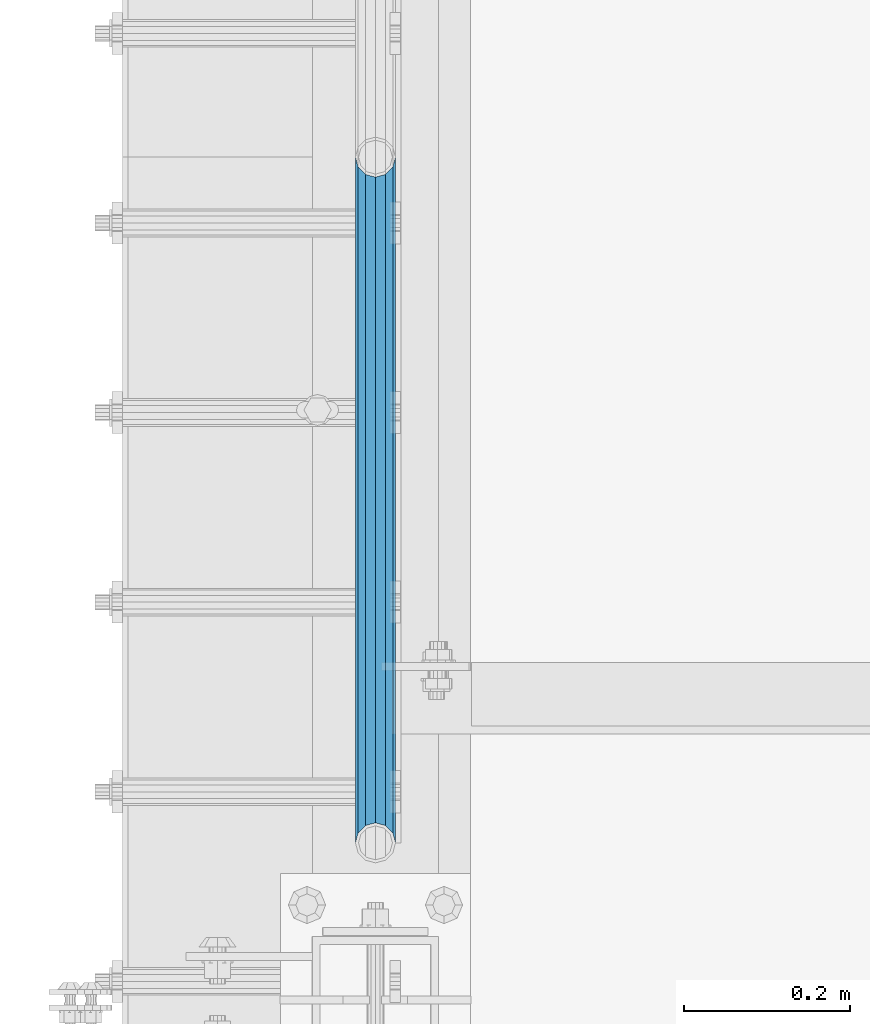
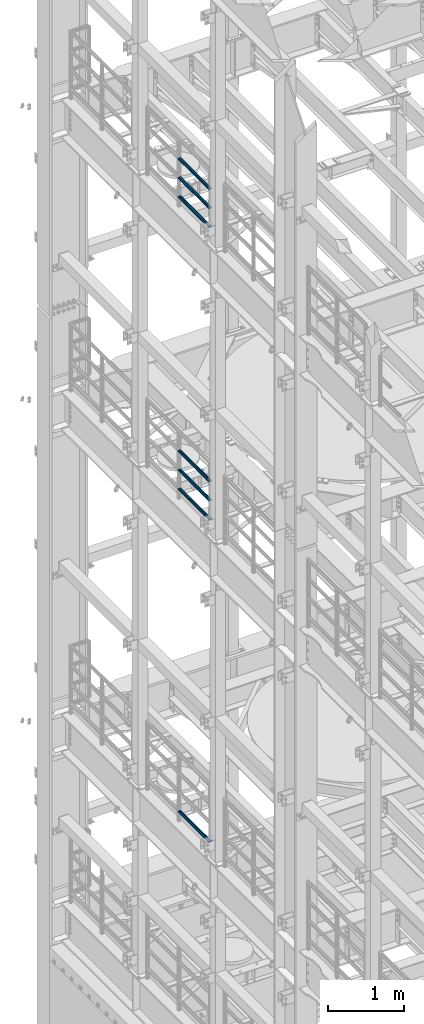
# One storey, part 1303 of 1876: 7 beams, 3 elements without a shape of their own.
"""IFC2X3 building model written with IfcOpenShell, lengths in millimetres."""

from ifc_helpers import new_model, si_unit, frame, origin_with_axes, place, context, subcontext, project, spatial, faceted_brep, material, type_object, element, aggregate, save


model = new_model("IFC2X3")

# Units and contexts
model_context = context("Model", 3, precision=1e-05, world=origin_with_axes())
body_context = subcontext(model_context, "Body", "Model", "MODEL_VIEW")
ifc_project = project(units=[si_unit("LENGTHUNIT", "METRE", prefix="MILLI"), si_unit("AREAUNIT", "SQUARE_METRE"), si_unit("VOLUMEUNIT", "CUBIC_METRE"), si_unit("MASSUNIT", "GRAM", prefix="KILO"), si_unit("TIMEUNIT", "SECOND"), si_unit("PLANEANGLEUNIT", "RADIAN"), si_unit("SOLIDANGLEUNIT", "STERADIAN"), si_unit("THERMODYNAMICTEMPERATUREUNIT", "DEGREE_CELSIUS"), si_unit("LUMINOUSINTENSITYUNIT", "LUMEN")], contexts=[model_context])

# Site, building, storey
site_placement = place(None, origin_with_axes())
site = spatial("IfcSite", under=ifc_project, at=site_placement, CompositionType="ELEMENT")
building_placement = place(site_placement, origin_with_axes())
building = spatial("IfcBuilding", under=site, at=building_placement, Name="Undefined", CompositionType="ELEMENT")
storey_placement = place(building_placement, origin_with_axes())
storey = spatial("IfcBuildingStorey", under=building, at=storey_placement, Name="Undefined", CompositionType="ELEMENT", Elevation=0.0)

# Assembly, beams
assembly_1_placement = place(storey_placement, origin_with_axes())
assembly_1 = element("IfcElementAssembly", 1, at=assembly_1_placement, inside=storey, Name="RAIL", AssemblyPlace="NOTDEFINED", PredefinedType="RIGID_FRAME")
ifc_material = material()
beam_type = type_object("IfcBeamType", Name="PIPE1-1/2SCH40", PredefinedType="NOTDEFINED")
beam_1_placement = place(assembly_1_placement, frame((-1.81898940354586e-12, 10668.0, 18145.125), z_axis=(0.0, 0.0, 1.0), x_axis=(0.0, -1.0, 0.0)))
beam_1 = element("IfcBeam", 2, at=beam_1_placement, type_object=beam_type, material=ifc_material, Name="RAIL", ObjectType="PIPE1-1/2SCH40", context=body_context, shape_type="Brep", body=[
    faceted_brep([(805.872807006681, -12.0649999999996, 20.8971929933177), (805.872807006683, -12.0649999999996, 15.8661214311796), (805.379378568819, -10.2235000000001, 17.7076214311819), (802.640000000001, 0.0, 20.4470000000001), (802.640000000001, 0.0, 24.130000000001), (805.379378568819, 10.2235000000001, 17.7076214311819), (805.872807006683, 12.0649999999996, 15.8661214311796), (805.872807006681, 12.0649999999996, 20.8971929933177), (826.77, 24.1300000000001, 0.0), (814.705, 20.8971929933186, 12.0649999999987), (814.705, 20.8971929933186, -12.0649999999987), (811.515428437862, 17.7076214311801, 10.2235000000001), (814.254807006682, 20.4470000000001, 0.0), (811.515428437862, 17.7076214311801, -10.2235000000001), (805.872807006683, 12.0649999999996, -15.8661214311796), (805.872807006681, 12.0649999999996, -20.8971929933177), (805.379378568819, 10.2235000000001, -17.7076214311819), (802.640000000001, 0.0, -20.4470000000001), (802.640000000001, 0.0, -24.130000000001), (805.872807006683, -12.0649999999996, -15.8661214311796), (805.872807006681, -12.0649999999996, -20.8971929933177), (805.379378568819, -10.2235000000001, -17.7076214311819), (826.77, -24.1300000000001, 0.0), (814.705, -20.8971929933186, -12.0649999999987), (814.705, -20.8971929933186, 12.0649999999987), (811.515428437862, -17.7076214311801, -10.2235000000001), (814.254807006682, -20.4470000000001, 0.0), (811.515428437862, -17.7076214311801, 10.2235000000001), (12.0650000000064, -20.8971929933177, -12.0649999999987), (20.8971929933249, -12.0650000000005, -20.8971929933177), (0.0, 24.1299999999992, 0.0), (12.0650000000064, 20.8971929933177, -12.0649999999987), (12.0650000000064, 20.8971929933177, 12.0649999999987), (20.8971929933249, 12.0650000000005, 20.8971929933177), (24.1300000000064, 0.0, 24.130000000001), (20.8971929933249, 12.0650000000005, -20.8971929933177), (24.1300000000063, 0.0, -24.130000000001), (24.1300000000063, 0.0, -20.4470000000001), (20.8971929933249, -12.0650000000005, -15.8661214311796), (21.3906214311868, -10.2235000000001, -17.7076214311819), (21.3906214311868, 10.2235000000001, -17.7076214311819), (20.8971929933249, 12.0650000000005, -15.8661214311796), (15.2545715621445, 17.7076214311801, -10.2235000000001), (12.5151929933249, 20.4470000000001, 0.0), (15.2545715621445, 17.7076214311801, 10.2235000000001), (20.8971929933249, 12.0650000000005, 15.8661214311796), (21.3906214311868, 10.2235000000001, 17.7076214311819), (24.1300000000064, 0.0, 20.4470000000001), (21.3906214311868, -10.2235000000001, 17.7076214311819), (20.8971929933249, -12.0650000000005, 15.8661214311796), (20.8971929933249, -12.0650000000005, 20.8971929933177), (12.0650000000064, -20.8971929933177, 12.0649999999987), (0.0, -24.1299999999992, 0.0), (15.2545715621445, -17.7076214311801, 10.2235000000001), (12.5151929933249, -20.4470000000001, 0.0), (15.2545715621445, -17.7076214311801, -10.2235000000001)], [[[0, 1, 2, 3, 4]], [[4, 3, 5, 6, 7]], [[8, 9, 10]], [[7, 6, 11, 12, 13, 14, 15, 10, 9]], [[16, 17, 18, 15, 14]], [[19, 20, 18, 17, 21]], [[22, 23, 24]], [[24, 23, 20, 19, 25, 26, 27, 1, 0]], [[28, 29, 20, 23]], [[30, 31, 32]], [[33, 34, 4, 7]], [[32, 33, 7, 9]], [[30, 32, 9, 8]], [[31, 30, 8, 10]], [[35, 31, 10, 15]], [[36, 35, 15, 18]], [[29, 36, 18, 20]], [[37, 36, 29, 38, 39]], [[40, 41, 35, 36, 37]], [[32, 31, 35, 41, 42, 43, 44, 45, 33]], [[33, 45, 46, 47, 34]], [[34, 47, 48, 49, 50]], [[34, 50, 0, 4]], [[50, 51, 24, 0]], [[51, 52, 22, 24]], [[52, 28, 23, 22]], [[51, 28, 52]], [[50, 49, 53, 54, 55, 38, 29, 28, 51]], [[55, 54, 26, 25]], [[21, 39, 38, 55, 25, 19]], [[37, 39, 21, 17]], [[40, 37, 17, 16]], [[42, 41, 40, 16, 14, 13]], [[43, 42, 13, 12]], [[44, 43, 12, 11]], [[5, 46, 45, 44, 11, 6]], [[47, 46, 5, 3]], [[48, 47, 3, 2]], [[53, 49, 48, 2, 1, 27]], [[54, 53, 27, 26]]]),
])
beam_2_placement = place(assembly_1_placement, frame((-1.81898940354586e-12, 9841.23, 18449.925), z_axis=(0.0, 0.0, -1.0), x_axis=(0.0, 1.0, 0.0)))
beam_2 = element("IfcBeam", 3, at=beam_2_placement, type_object=beam_type, material=ifc_material, Name="RAIL", ObjectType="PIPE1-1/2SCH40", context=body_context, shape_type="Brep", body=[
    faceted_brep([(0.0, 24.1299999999992, 0.0), (12.0650000000064, 20.8971929933177, -12.0649999999987), (12.0650000000064, 20.8971929933177, 12.0649999999987), (12.0650000000064, -20.8971929933177, 12.0649999999987), (12.0650000000064, -20.8971929933177, -12.0649999999987), (0.0, -24.1299999999992, 0.0), (20.8971929933249, -12.0650000000005, 20.8971929933177), (20.8971929933249, -12.0650000000005, 15.8661214311796), (15.2545715621445, -17.7076214311801, 10.2235000000001), (12.5151929933249, -20.4470000000001, 0.0), (15.2545715621445, -17.7076214311801, -10.2235000000001), (20.8971929933249, -12.0650000000005, -15.8661214311796), (20.8971929933249, -12.0650000000005, -20.8971929933177), (24.1300000000063, 0.0, -20.4470000000001), (24.1300000000063, 0.0, -24.130000000001), (21.3906214311868, -10.2235000000001, -17.7076214311819), (21.3906214311868, 10.2235000000001, -17.7076214311819), (20.8971929933249, 12.0650000000005, -15.8661214311796), (20.8971929933249, 12.0650000000005, -20.8971929933177), (15.2545715621445, 17.7076214311801, -10.2235000000001), (12.5151929933249, 20.4470000000001, 0.0), (15.2545715621445, 17.7076214311801, 10.2235000000001), (20.8971929933249, 12.0650000000005, 15.8661214311796), (20.8971929933249, 12.0650000000005, 20.8971929933177), (21.3906214311868, 10.2235000000001, 17.7076214311819), (24.1300000000064, 0.0, 20.4470000000001), (24.1300000000064, 0.0, 24.130000000001), (21.3906214311868, -10.2235000000001, 17.7076214311819), (826.77, 24.1300000000001, 0.0), (814.705, 20.8971929933186, -12.0649999999987), (805.872807006681, 12.0649999999996, -20.8971929933177), (826.77, -24.1300000000001, 0.0), (814.705, -20.8971929933186, -12.0649999999987), (814.705, -20.8971929933186, 12.0649999999987), (805.872807006681, -12.0649999999996, 20.8971929933177), (805.872807006681, -12.0649999999996, -20.8971929933177), (802.640000000001, 0.0, -24.130000000001), (805.379378568819, 10.2235000000001, -17.7076214311819), (802.640000000001, 0.0, -20.4470000000001), (805.872807006683, 12.0649999999996, -15.8661214311796), (805.872807006683, -12.0649999999996, -15.8661214311796), (805.379378568819, -10.2235000000001, -17.7076214311819), (811.515428437862, -17.7076214311801, -10.2235000000001), (814.254807006682, -20.4470000000001, 0.0), (811.515428437862, -17.7076214311801, 10.2235000000001), (805.872807006683, -12.0649999999996, 15.8661214311796), (805.379378568819, -10.2235000000001, 17.7076214311819), (802.640000000001, 0.0, 20.4470000000001), (802.640000000001, 0.0, 24.130000000001), (805.872807006681, 12.0649999999996, 20.8971929933177), (814.705, 20.8971929933186, 12.0649999999987), (805.872807006683, 12.0649999999996, 15.8661214311796), (811.515428437862, 17.7076214311801, 10.2235000000001), (814.254807006682, 20.4470000000001, 0.0), (811.515428437862, 17.7076214311801, -10.2235000000001), (805.379378568819, 10.2235000000001, 17.7076214311819)], [[[0, 1, 2]], [[3, 4, 5]], [[6, 7, 8, 9, 10, 11, 12, 4, 3]], [[13, 14, 12, 11, 15]], [[16, 17, 18, 14, 13]], [[2, 1, 18, 17, 19, 20, 21, 22, 23]], [[23, 22, 24, 25, 26]], [[26, 25, 27, 7, 6]], [[1, 0, 28, 29]], [[18, 1, 29, 30]], [[31, 32, 33]], [[6, 3, 33, 34]], [[3, 5, 31, 33]], [[5, 4, 32, 31]], [[4, 12, 35, 32]], [[12, 14, 36, 35]], [[14, 18, 30, 36]], [[37, 38, 36, 30, 39]], [[40, 35, 36, 38, 41]], [[33, 32, 35, 40, 42, 43, 44, 45, 34]], [[34, 45, 46, 47, 48]], [[26, 6, 34, 48]], [[2, 23, 49, 50]], [[23, 26, 48, 49]], [[0, 2, 50, 28]], [[28, 50, 29]], [[49, 51, 52, 53, 54, 39, 30, 29, 50]], [[48, 47, 55, 51, 49]], [[25, 24, 55, 47]], [[55, 24, 22, 21, 52, 51]], [[21, 20, 53, 52]], [[20, 19, 54, 53]], [[19, 17, 16, 37, 39, 54]], [[16, 13, 38, 37]], [[13, 15, 41, 38]], [[41, 15, 11, 10, 42, 40]], [[10, 9, 43, 42]], [[9, 8, 44, 43]], [[8, 7, 27, 46, 45, 44]], [[27, 25, 47, 46]]]),
])
beam_3_placement = place(assembly_1_placement, frame((-1.81898940354586e-12, 9841.23, 18754.725), z_axis=(0.0, 0.0, -1.0), x_axis=(0.0, 1.0, 0.0)))
beam_3 = element("IfcBeam", 4, at=beam_3_placement, type_object=beam_type, material=ifc_material, Name="RAIL", ObjectType="PIPE1-1/2SCH40", context=body_context, shape_type="Brep", body=[
    faceted_brep([(0.0, 24.1299999999992, 0.0), (12.0650000000064, 20.8971929933177, -12.0649999999987), (12.0650000000064, 20.8971929933177, 12.0649999999987), (12.0650000000064, -20.8971929933177, 12.0649999999987), (12.0650000000064, -20.8971929933177, -12.0649999999987), (0.0, -24.1299999999992, 0.0), (20.8971929933249, -12.0650000000005, 20.8971929933177), (20.8971929933249, -12.0650000000005, 15.8661214311796), (15.2545715621445, -17.7076214311801, 10.2235000000001), (12.5151929933249, -20.4470000000001, 0.0), (15.2545715621445, -17.7076214311801, -10.2235000000001), (20.8971929933249, -12.0650000000005, -15.8661214311796), (20.8971929933249, -12.0650000000005, -20.8971929933177), (24.1300000000063, 0.0, -20.4470000000001), (24.1300000000063, 0.0, -24.130000000001), (21.3906214311868, -10.2235000000001, -17.7076214311819), (21.3906214311868, 10.2235000000001, -17.7076214311819), (20.8971929933249, 12.0650000000005, -15.8661214311796), (20.8971929933249, 12.0650000000005, -20.8971929933177), (15.2545715621445, 17.7076214311801, -10.2235000000001), (12.5151929933249, 20.4470000000001, 0.0), (15.2545715621445, 17.7076214311801, 10.2235000000001), (20.8971929933249, 12.0650000000005, 15.8661214311796), (20.8971929933249, 12.0650000000005, 20.8971929933177), (21.3906214311868, 10.2235000000001, 17.7076214311819), (24.1300000000064, 0.0, 20.4470000000001), (24.1300000000064, 0.0, 24.130000000001), (21.3906214311868, -10.2235000000001, 17.7076214311819), (826.77, 24.1300000000001, 0.0), (814.705, 20.8971929933186, -12.0649999999987), (805.872807006681, 12.0649999999996, -20.8971929933177), (826.77, -24.1300000000001, 0.0), (814.705, -20.8971929933186, -12.0649999999987), (814.705, -20.8971929933186, 12.0649999999987), (805.872807006681, -12.0649999999996, 20.8971929933177), (805.872807006681, -12.0649999999996, -20.8971929933177), (802.640000000001, 0.0, -24.130000000001), (805.379378568819, 10.2235000000001, -17.7076214311819), (802.640000000001, 0.0, -20.4470000000001), (805.872807006683, 12.0649999999996, -15.8661214311796), (805.872807006683, -12.0649999999996, -15.8661214311796), (805.379378568819, -10.2235000000001, -17.7076214311819), (811.515428437862, -17.7076214311801, -10.2235000000001), (814.254807006682, -20.4470000000001, 0.0), (811.515428437862, -17.7076214311801, 10.2235000000001), (805.872807006683, -12.0649999999996, 15.8661214311796), (805.379378568819, -10.2235000000001, 17.7076214311819), (802.640000000001, 0.0, 20.4470000000001), (802.640000000001, 0.0, 24.130000000001), (805.872807006681, 12.0649999999996, 20.8971929933177), (814.705, 20.8971929933186, 12.0649999999987), (805.872807006683, 12.0649999999996, 15.8661214311796), (811.515428437862, 17.7076214311801, 10.2235000000001), (814.254807006682, 20.4470000000001, 0.0), (811.515428437862, 17.7076214311801, -10.2235000000001), (805.379378568819, 10.2235000000001, 17.7076214311819)], [[[0, 1, 2]], [[3, 4, 5]], [[6, 7, 8, 9, 10, 11, 12, 4, 3]], [[13, 14, 12, 11, 15]], [[16, 17, 18, 14, 13]], [[2, 1, 18, 17, 19, 20, 21, 22, 23]], [[23, 22, 24, 25, 26]], [[26, 25, 27, 7, 6]], [[1, 0, 28, 29]], [[18, 1, 29, 30]], [[31, 32, 33]], [[6, 3, 33, 34]], [[3, 5, 31, 33]], [[5, 4, 32, 31]], [[4, 12, 35, 32]], [[12, 14, 36, 35]], [[14, 18, 30, 36]], [[37, 38, 36, 30, 39]], [[40, 35, 36, 38, 41]], [[33, 32, 35, 40, 42, 43, 44, 45, 34]], [[34, 45, 46, 47, 48]], [[26, 6, 34, 48]], [[2, 23, 49, 50]], [[23, 26, 48, 49]], [[0, 2, 50, 28]], [[28, 50, 29]], [[49, 51, 52, 53, 54, 39, 30, 29, 50]], [[48, 47, 55, 51, 49]], [[25, 24, 55, 47]], [[55, 24, 22, 21, 52, 51]], [[21, 20, 53, 52]], [[20, 19, 54, 53]], [[19, 17, 16, 37, 39, 54]], [[16, 13, 38, 37]], [[13, 15, 41, 38]], [[41, 15, 11, 10, 42, 40]], [[10, 9, 43, 42]], [[9, 8, 44, 43]], [[8, 7, 27, 46, 45, 44]], [[27, 25, 47, 46]]]),
])
aggregate(assembly_1, [beam_1, beam_2, beam_3])

assembly_2_placement = place(storey_placement, origin_with_axes())
assembly_2 = element("IfcElementAssembly", 5, at=assembly_2_placement, inside=storey, Name="RAIL", AssemblyPlace="NOTDEFINED", PredefinedType="RIGID_FRAME")
beam_4_placement = place(assembly_2_placement, frame((-1.81898940354586e-12, 10668.0, 13471.525), z_axis=(0.0, 0.0, 1.0), x_axis=(0.0, -1.0, 0.0)))
beam_4 = element("IfcBeam", 6, at=beam_4_placement, type_object=beam_type, material=ifc_material, Name="RAIL", ObjectType="PIPE1-1/2SCH40", context=body_context, shape_type="Brep", body=[
    faceted_brep([(805.872807006681, -12.0649999999996, 20.8971929933177), (805.872807006683, -12.0649999999996, 15.8661214311796), (805.379378568819, -10.2235000000001, 17.7076214311819), (802.640000000001, 0.0, 20.4470000000001), (802.640000000001, 0.0, 24.130000000001), (805.379378568819, 10.2235000000001, 17.7076214311819), (805.872807006683, 12.0649999999996, 15.8661214311796), (805.872807006681, 12.0649999999996, 20.8971929933177), (826.77, 24.1300000000001, 0.0), (814.705, 20.8971929933186, 12.0649999999987), (814.705, 20.8971929933186, -12.0649999999987), (811.515428437862, 17.7076214311801, 10.2235000000001), (814.254807006682, 20.4470000000001, 0.0), (811.515428437862, 17.7076214311801, -10.2235000000001), (805.872807006683, 12.0649999999996, -15.8661214311796), (805.872807006681, 12.0649999999996, -20.8971929933177), (805.379378568819, 10.2235000000001, -17.7076214311819), (802.640000000001, 0.0, -20.4470000000001), (802.640000000001, 0.0, -24.130000000001), (805.872807006683, -12.0649999999996, -15.8661214311796), (805.872807006681, -12.0649999999996, -20.8971929933177), (805.379378568819, -10.2235000000001, -17.7076214311819), (826.77, -24.1300000000001, 0.0), (814.705, -20.8971929933186, -12.0649999999987), (814.705, -20.8971929933186, 12.0649999999987), (811.515428437862, -17.7076214311801, -10.2235000000001), (814.254807006682, -20.4470000000001, 0.0), (811.515428437862, -17.7076214311801, 10.2235000000001), (12.0650000000064, -20.8971929933177, -12.0649999999987), (20.8971929933249, -12.0650000000005, -20.8971929933177), (0.0, 24.1299999999992, 0.0), (12.0650000000064, 20.8971929933177, -12.0649999999987), (12.0650000000064, 20.8971929933177, 12.0649999999987), (20.8971929933249, 12.0650000000005, 20.8971929933177), (24.1300000000064, 0.0, 24.130000000001), (20.8971929933249, 12.0650000000005, -20.8971929933177), (24.1300000000063, 0.0, -24.130000000001), (24.1300000000063, 0.0, -20.4470000000001), (20.8971929933249, -12.0650000000005, -15.8661214311796), (21.3906214311868, -10.2235000000001, -17.7076214311819), (21.3906214311868, 10.2235000000001, -17.7076214311819), (20.8971929933249, 12.0650000000005, -15.8661214311796), (15.2545715621445, 17.7076214311801, -10.2235000000001), (12.5151929933249, 20.4470000000001, 0.0), (15.2545715621445, 17.7076214311801, 10.2235000000001), (20.8971929933249, 12.0650000000005, 15.8661214311796), (21.3906214311868, 10.2235000000001, 17.7076214311819), (24.1300000000064, 0.0, 20.4470000000001), (21.3906214311868, -10.2235000000001, 17.7076214311819), (20.8971929933249, -12.0650000000005, 15.8661214311796), (20.8971929933249, -12.0650000000005, 20.8971929933177), (12.0650000000064, -20.8971929933177, 12.0649999999987), (0.0, -24.1299999999992, 0.0), (15.2545715621445, -17.7076214311801, 10.2235000000001), (12.5151929933249, -20.4470000000001, 0.0), (15.2545715621445, -17.7076214311801, -10.2235000000001)], [[[0, 1, 2, 3, 4]], [[4, 3, 5, 6, 7]], [[8, 9, 10]], [[7, 6, 11, 12, 13, 14, 15, 10, 9]], [[16, 17, 18, 15, 14]], [[19, 20, 18, 17, 21]], [[22, 23, 24]], [[24, 23, 20, 19, 25, 26, 27, 1, 0]], [[28, 29, 20, 23]], [[30, 31, 32]], [[33, 34, 4, 7]], [[32, 33, 7, 9]], [[30, 32, 9, 8]], [[31, 30, 8, 10]], [[35, 31, 10, 15]], [[36, 35, 15, 18]], [[29, 36, 18, 20]], [[37, 36, 29, 38, 39]], [[40, 41, 35, 36, 37]], [[32, 31, 35, 41, 42, 43, 44, 45, 33]], [[33, 45, 46, 47, 34]], [[34, 47, 48, 49, 50]], [[34, 50, 0, 4]], [[50, 51, 24, 0]], [[51, 52, 22, 24]], [[52, 28, 23, 22]], [[51, 28, 52]], [[50, 49, 53, 54, 55, 38, 29, 28, 51]], [[55, 54, 26, 25]], [[21, 39, 38, 55, 25, 19]], [[37, 39, 21, 17]], [[40, 37, 17, 16]], [[42, 41, 40, 16, 14, 13]], [[43, 42, 13, 12]], [[44, 43, 12, 11]], [[5, 46, 45, 44, 11, 6]], [[47, 46, 5, 3]], [[48, 47, 3, 2]], [[53, 49, 48, 2, 1, 27]], [[54, 53, 27, 26]]]),
])
beam_5_placement = place(assembly_2_placement, frame((-1.81898940354586e-12, 9841.23, 13776.325), z_axis=(0.0, 0.0, -1.0), x_axis=(0.0, 1.0, 0.0)))
beam_5 = element("IfcBeam", 7, at=beam_5_placement, type_object=beam_type, material=ifc_material, Name="RAIL", ObjectType="PIPE1-1/2SCH40", context=body_context, shape_type="Brep", body=[
    faceted_brep([(0.0, 24.1299999999992, 0.0), (12.0650000000064, 20.8971929933177, -12.0649999999987), (12.0650000000064, 20.8971929933177, 12.0649999999987), (12.0650000000064, -20.8971929933177, 12.0649999999987), (12.0650000000064, -20.8971929933177, -12.0649999999987), (0.0, -24.1299999999992, 0.0), (20.8971929933249, -12.0650000000005, 20.8971929933177), (20.8971929933249, -12.0650000000005, 15.8661214311796), (15.2545715621445, -17.7076214311801, 10.2235000000001), (12.5151929933249, -20.4470000000001, 0.0), (15.2545715621445, -17.7076214311801, -10.2235000000001), (20.8971929933249, -12.0650000000005, -15.8661214311796), (20.8971929933249, -12.0650000000005, -20.8971929933177), (24.1300000000063, 0.0, -20.4470000000001), (24.1300000000063, 0.0, -24.130000000001), (21.3906214311868, -10.2235000000001, -17.7076214311819), (21.3906214311868, 10.2235000000001, -17.7076214311819), (20.8971929933249, 12.0650000000005, -15.8661214311796), (20.8971929933249, 12.0650000000005, -20.8971929933177), (15.2545715621445, 17.7076214311801, -10.2235000000001), (12.5151929933249, 20.4470000000001, 0.0), (15.2545715621445, 17.7076214311801, 10.2235000000001), (20.8971929933249, 12.0650000000005, 15.8661214311796), (20.8971929933249, 12.0650000000005, 20.8971929933177), (21.3906214311868, 10.2235000000001, 17.7076214311819), (24.1300000000064, 0.0, 20.4470000000001), (24.1300000000064, 0.0, 24.130000000001), (21.3906214311868, -10.2235000000001, 17.7076214311819), (826.77, 24.1300000000001, 0.0), (814.705, 20.8971929933186, -12.0649999999987), (805.872807006681, 12.0649999999996, -20.8971929933177), (826.77, -24.1300000000001, 0.0), (814.705, -20.8971929933186, -12.0649999999987), (814.705, -20.8971929933186, 12.0649999999987), (805.872807006681, -12.0649999999996, 20.8971929933177), (805.872807006681, -12.0649999999996, -20.8971929933177), (802.640000000001, 0.0, -24.130000000001), (805.379378568819, 10.2235000000001, -17.7076214311819), (802.640000000001, 0.0, -20.4470000000001), (805.872807006683, 12.0649999999996, -15.8661214311796), (805.872807006683, -12.0649999999996, -15.8661214311796), (805.379378568819, -10.2235000000001, -17.7076214311819), (811.515428437862, -17.7076214311801, -10.2235000000001), (814.254807006682, -20.4470000000001, 0.0), (811.515428437862, -17.7076214311801, 10.2235000000001), (805.872807006683, -12.0649999999996, 15.8661214311796), (805.379378568819, -10.2235000000001, 17.7076214311819), (802.640000000001, 0.0, 20.4470000000001), (802.640000000001, 0.0, 24.130000000001), (805.872807006681, 12.0649999999996, 20.8971929933177), (814.705, 20.8971929933186, 12.0649999999987), (805.872807006683, 12.0649999999996, 15.8661214311796), (811.515428437862, 17.7076214311801, 10.2235000000001), (814.254807006682, 20.4470000000001, 0.0), (811.515428437862, 17.7076214311801, -10.2235000000001), (805.379378568819, 10.2235000000001, 17.7076214311819)], [[[0, 1, 2]], [[3, 4, 5]], [[6, 7, 8, 9, 10, 11, 12, 4, 3]], [[13, 14, 12, 11, 15]], [[16, 17, 18, 14, 13]], [[2, 1, 18, 17, 19, 20, 21, 22, 23]], [[23, 22, 24, 25, 26]], [[26, 25, 27, 7, 6]], [[1, 0, 28, 29]], [[18, 1, 29, 30]], [[31, 32, 33]], [[6, 3, 33, 34]], [[3, 5, 31, 33]], [[5, 4, 32, 31]], [[4, 12, 35, 32]], [[12, 14, 36, 35]], [[14, 18, 30, 36]], [[37, 38, 36, 30, 39]], [[40, 35, 36, 38, 41]], [[33, 32, 35, 40, 42, 43, 44, 45, 34]], [[34, 45, 46, 47, 48]], [[26, 6, 34, 48]], [[2, 23, 49, 50]], [[23, 26, 48, 49]], [[0, 2, 50, 28]], [[28, 50, 29]], [[49, 51, 52, 53, 54, 39, 30, 29, 50]], [[48, 47, 55, 51, 49]], [[25, 24, 55, 47]], [[55, 24, 22, 21, 52, 51]], [[21, 20, 53, 52]], [[20, 19, 54, 53]], [[19, 17, 16, 37, 39, 54]], [[16, 13, 38, 37]], [[13, 15, 41, 38]], [[41, 15, 11, 10, 42, 40]], [[10, 9, 43, 42]], [[9, 8, 44, 43]], [[8, 7, 27, 46, 45, 44]], [[27, 25, 47, 46]]]),
])
beam_6_placement = place(assembly_2_placement, frame((-1.81898940354586e-12, 9841.23, 14081.125), z_axis=(0.0, 0.0, -1.0), x_axis=(0.0, 1.0, 0.0)))
beam_6 = element("IfcBeam", 8, at=beam_6_placement, type_object=beam_type, material=ifc_material, Name="RAIL", ObjectType="PIPE1-1/2SCH40", context=body_context, shape_type="Brep", body=[
    faceted_brep([(0.0, 24.1299999999992, 0.0), (12.0650000000064, 20.8971929933177, -12.0649999999987), (12.0650000000064, 20.8971929933177, 12.0649999999987), (12.0650000000064, -20.8971929933177, 12.0649999999987), (12.0650000000064, -20.8971929933177, -12.0649999999987), (0.0, -24.1299999999992, 0.0), (20.8971929933249, -12.0650000000005, 20.8971929933177), (20.8971929933249, -12.0650000000005, 15.8661214311796), (15.2545715621445, -17.7076214311801, 10.2235000000001), (12.5151929933249, -20.4470000000001, 0.0), (15.2545715621445, -17.7076214311801, -10.2235000000001), (20.8971929933249, -12.0650000000005, -15.8661214311796), (20.8971929933249, -12.0650000000005, -20.8971929933177), (24.1300000000063, 0.0, -20.4470000000001), (24.1300000000063, 0.0, -24.130000000001), (21.3906214311868, -10.2235000000001, -17.7076214311819), (21.3906214311868, 10.2235000000001, -17.7076214311819), (20.8971929933249, 12.0650000000005, -15.8661214311796), (20.8971929933249, 12.0650000000005, -20.8971929933177), (15.2545715621445, 17.7076214311801, -10.2235000000001), (12.5151929933249, 20.4470000000001, 0.0), (15.2545715621445, 17.7076214311801, 10.2235000000001), (20.8971929933249, 12.0650000000005, 15.8661214311796), (20.8971929933249, 12.0650000000005, 20.8971929933177), (21.3906214311868, 10.2235000000001, 17.7076214311819), (24.1300000000064, 0.0, 20.4470000000001), (24.1300000000064, 0.0, 24.130000000001), (21.3906214311868, -10.2235000000001, 17.7076214311819), (826.77, 24.1300000000001, 0.0), (814.705, 20.8971929933186, -12.0649999999987), (805.872807006681, 12.0649999999996, -20.8971929933177), (826.77, -24.1300000000001, 0.0), (814.705, -20.8971929933186, -12.0649999999987), (814.705, -20.8971929933186, 12.0649999999987), (805.872807006681, -12.0649999999996, 20.8971929933177), (805.872807006681, -12.0649999999996, -20.8971929933177), (802.640000000001, 0.0, -24.130000000001), (805.379378568819, 10.2235000000001, -17.7076214311819), (802.640000000001, 0.0, -20.4470000000001), (805.872807006683, 12.0649999999996, -15.8661214311796), (805.872807006683, -12.0649999999996, -15.8661214311796), (805.379378568819, -10.2235000000001, -17.7076214311819), (811.515428437862, -17.7076214311801, -10.2235000000001), (814.254807006682, -20.4470000000001, 0.0), (811.515428437862, -17.7076214311801, 10.2235000000001), (805.872807006683, -12.0649999999996, 15.8661214311796), (805.379378568819, -10.2235000000001, 17.7076214311819), (802.640000000001, 0.0, 20.4470000000001), (802.640000000001, 0.0, 24.130000000001), (805.872807006681, 12.0649999999996, 20.8971929933177), (814.705, 20.8971929933186, 12.0649999999987), (805.872807006683, 12.0649999999996, 15.8661214311796), (811.515428437862, 17.7076214311801, 10.2235000000001), (814.254807006682, 20.4470000000001, 0.0), (811.515428437862, 17.7076214311801, -10.2235000000001), (805.379378568819, 10.2235000000001, 17.7076214311819)], [[[0, 1, 2]], [[3, 4, 5]], [[6, 7, 8, 9, 10, 11, 12, 4, 3]], [[13, 14, 12, 11, 15]], [[16, 17, 18, 14, 13]], [[2, 1, 18, 17, 19, 20, 21, 22, 23]], [[23, 22, 24, 25, 26]], [[26, 25, 27, 7, 6]], [[1, 0, 28, 29]], [[18, 1, 29, 30]], [[31, 32, 33]], [[6, 3, 33, 34]], [[3, 5, 31, 33]], [[5, 4, 32, 31]], [[4, 12, 35, 32]], [[12, 14, 36, 35]], [[14, 18, 30, 36]], [[37, 38, 36, 30, 39]], [[40, 35, 36, 38, 41]], [[33, 32, 35, 40, 42, 43, 44, 45, 34]], [[34, 45, 46, 47, 48]], [[26, 6, 34, 48]], [[2, 23, 49, 50]], [[23, 26, 48, 49]], [[0, 2, 50, 28]], [[28, 50, 29]], [[49, 51, 52, 53, 54, 39, 30, 29, 50]], [[48, 47, 55, 51, 49]], [[25, 24, 55, 47]], [[55, 24, 22, 21, 52, 51]], [[21, 20, 53, 52]], [[20, 19, 54, 53]], [[19, 17, 16, 37, 39, 54]], [[16, 13, 38, 37]], [[13, 15, 41, 38]], [[41, 15, 11, 10, 42, 40]], [[10, 9, 43, 42]], [[9, 8, 44, 43]], [[8, 7, 27, 46, 45, 44]], [[27, 25, 47, 46]]]),
])
aggregate(assembly_2, [beam_4, beam_5, beam_6])

# Assembly, beam
assembly_3_placement = place(storey_placement, origin_with_axes())
assembly_3 = element("IfcElementAssembly", 9, at=assembly_3_placement, inside=storey, Name="RAIL", AssemblyPlace="NOTDEFINED", PredefinedType="RIGID_FRAME")
beam_7_placement = place(assembly_3_placement, frame((-1.81898940354586e-12, 10668.0, 8315.325), z_axis=(0.0, 0.0, 1.0), x_axis=(0.0, -1.0, 0.0)))
beam_7 = element("IfcBeam", 10, at=beam_7_placement, type_object=beam_type, material=ifc_material, Name="RAIL", ObjectType="PIPE1-1/2SCH40", context=body_context, shape_type="Brep", body=[
    faceted_brep([(805.872807006681, -12.0649999999996, 20.8971929933177), (805.872807006683, -12.0649999999996, 15.8661214311796), (805.379378568819, -10.2235000000001, 17.7076214311819), (802.640000000001, 0.0, 20.4470000000001), (802.640000000001, 0.0, 24.130000000001), (805.379378568819, 10.2235000000001, 17.7076214311819), (805.872807006683, 12.0649999999996, 15.8661214311796), (805.872807006681, 12.0649999999996, 20.8971929933177), (826.77, 24.1300000000001, 0.0), (814.705, 20.8971929933186, 12.0649999999987), (814.705, 20.8971929933186, -12.0649999999987), (811.515428437862, 17.7076214311801, 10.2235000000001), (814.254807006682, 20.4470000000001, 0.0), (811.515428437862, 17.7076214311801, -10.2235000000001), (805.872807006683, 12.0649999999996, -15.8661214311796), (805.872807006681, 12.0649999999996, -20.8971929933177), (805.379378568819, 10.2235000000001, -17.7076214311819), (802.640000000001, 0.0, -20.4470000000001), (802.640000000001, 0.0, -24.130000000001), (805.872807006683, -12.0649999999996, -15.8661214311796), (805.872807006681, -12.0649999999996, -20.8971929933177), (805.379378568819, -10.2235000000001, -17.7076214311819), (826.77, -24.1300000000001, 0.0), (814.705, -20.8971929933186, -12.0649999999987), (814.705, -20.8971929933186, 12.0649999999987), (811.515428437862, -17.7076214311801, -10.2235000000001), (814.254807006682, -20.4470000000001, 0.0), (811.515428437862, -17.7076214311801, 10.2235000000001), (12.0650000000064, -20.8971929933177, -12.0649999999987), (20.8971929933249, -12.0650000000005, -20.8971929933177), (0.0, 24.1299999999992, 0.0), (12.0650000000064, 20.8971929933177, -12.0649999999987), (12.0650000000064, 20.8971929933177, 12.0649999999987), (20.8971929933249, 12.0650000000005, 20.8971929933177), (24.1300000000064, 0.0, 24.130000000001), (20.8971929933249, 12.0650000000005, -20.8971929933177), (24.1300000000063, 0.0, -24.130000000001), (24.1300000000063, 0.0, -20.4470000000001), (20.8971929933249, -12.0650000000005, -15.8661214311796), (21.3906214311868, -10.2235000000001, -17.7076214311819), (21.3906214311868, 10.2235000000001, -17.7076214311819), (20.8971929933249, 12.0650000000005, -15.8661214311796), (15.2545715621445, 17.7076214311801, -10.2235000000001), (12.5151929933249, 20.4470000000001, 0.0), (15.2545715621445, 17.7076214311801, 10.2235000000001), (20.8971929933249, 12.0650000000005, 15.8661214311796), (21.3906214311868, 10.2235000000001, 17.7076214311819), (24.1300000000064, 0.0, 20.4470000000001), (21.3906214311868, -10.2235000000001, 17.7076214311819), (20.8971929933249, -12.0650000000005, 15.8661214311796), (20.8971929933249, -12.0650000000005, 20.8971929933177), (12.0650000000064, -20.8971929933177, 12.0649999999987), (0.0, -24.1299999999992, 0.0), (15.2545715621445, -17.7076214311801, 10.2235000000001), (12.5151929933249, -20.4470000000001, 0.0), (15.2545715621445, -17.7076214311801, -10.2235000000001)], [[[0, 1, 2, 3, 4]], [[4, 3, 5, 6, 7]], [[8, 9, 10]], [[7, 6, 11, 12, 13, 14, 15, 10, 9]], [[16, 17, 18, 15, 14]], [[19, 20, 18, 17, 21]], [[22, 23, 24]], [[24, 23, 20, 19, 25, 26, 27, 1, 0]], [[28, 29, 20, 23]], [[30, 31, 32]], [[33, 34, 4, 7]], [[32, 33, 7, 9]], [[30, 32, 9, 8]], [[31, 30, 8, 10]], [[35, 31, 10, 15]], [[36, 35, 15, 18]], [[29, 36, 18, 20]], [[37, 36, 29, 38, 39]], [[40, 41, 35, 36, 37]], [[32, 31, 35, 41, 42, 43, 44, 45, 33]], [[33, 45, 46, 47, 34]], [[34, 47, 48, 49, 50]], [[34, 50, 0, 4]], [[50, 51, 24, 0]], [[51, 52, 22, 24]], [[52, 28, 23, 22]], [[51, 28, 52]], [[50, 49, 53, 54, 55, 38, 29, 28, 51]], [[55, 54, 26, 25]], [[21, 39, 38, 55, 25, 19]], [[37, 39, 21, 17]], [[40, 37, 17, 16]], [[42, 41, 40, 16, 14, 13]], [[43, 42, 13, 12]], [[44, 43, 12, 11]], [[5, 46, 45, 44, 11, 6]], [[47, 46, 5, 3]], [[48, 47, 3, 2]], [[53, 49, 48, 2, 1, 27]], [[54, 53, 27, 26]]]),
])
aggregate(assembly_3, [beam_7])

save(model, "model.ifc")
